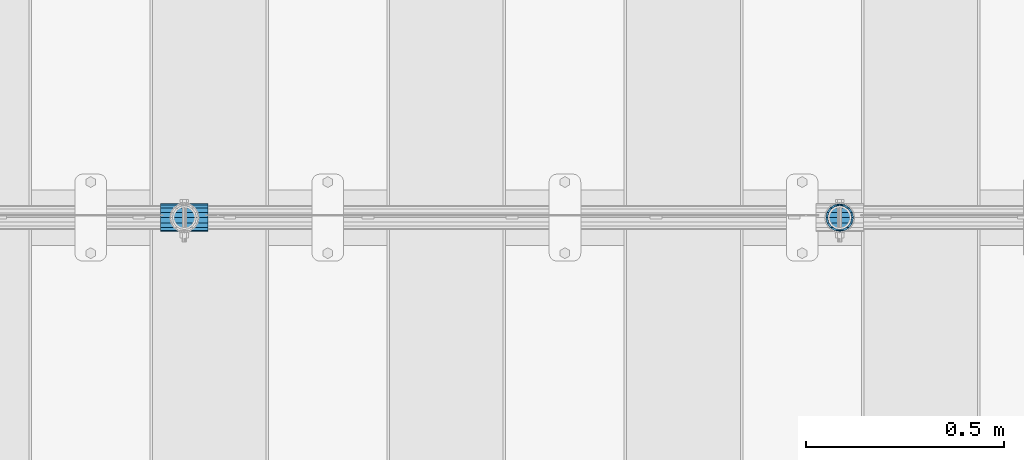
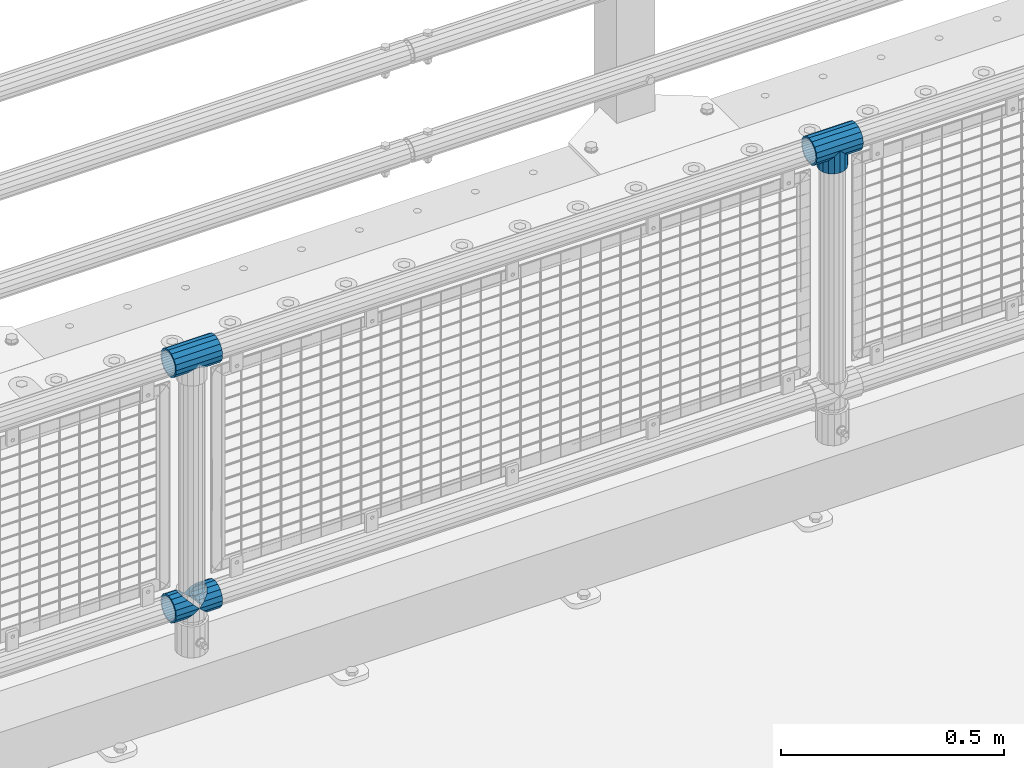
# One storey, part 139 of 219: 5 beams.
"""IFC2X3 building model written with IfcOpenShell, lengths in millimetres."""

from ifc_helpers import new_model, si_unit, frame, origin_with_axes, place, context, subcontext, project, spatial, faceted_brep, material, type_object, element, save


model = new_model("IFC2X3")

# Units and contexts
model_context = context("Model", 3, precision=1e-05, world=origin_with_axes())
body_context = subcontext(model_context, "Body", "Model", "MODEL_VIEW")
ifc_project = project(units=[si_unit("LENGTHUNIT", "METRE", prefix="MILLI"), si_unit("AREAUNIT", "SQUARE_METRE"), si_unit("VOLUMEUNIT", "CUBIC_METRE"), si_unit("MASSUNIT", "GRAM", prefix="KILO"), si_unit("TIMEUNIT", "SECOND"), si_unit("PLANEANGLEUNIT", "RADIAN"), si_unit("SOLIDANGLEUNIT", "STERADIAN"), si_unit("THERMODYNAMICTEMPERATUREUNIT", "DEGREE_CELSIUS"), si_unit("LUMINOUSINTENSITYUNIT", "LUMEN")], contexts=[model_context])

# Site, building, storey
site_placement = place(None, origin_with_axes())
site = spatial("IfcSite", under=ifc_project, at=site_placement, CompositionType="ELEMENT")
building_placement = place(site_placement, origin_with_axes())
building = spatial("IfcBuilding", under=site, at=building_placement, Name="Standard", CompositionType="ELEMENT")
storey_placement = place(building_placement, origin_with_axes())
storey = spatial("IfcBuildingStorey", under=building, at=storey_placement, Name="Undefined", CompositionType="ELEMENT", Elevation=0.0)

# Beams
ifc_material = material(Name="Misc_Undefined")
beam_type = type_object("IfcBeamType", PredefinedType="NOTDEFINED")
beam_1_placement = place(storey_placement, frame((5595.0, 31664.5, 969.849999999999), z_axis=(0.0, 1.0, 0.0), x_axis=(0.0, 0.0, -1.0)))
element("IfcBeam", 1, at=beam_1_placement, inside=storey, type_object=beam_type, material=ifc_material, context=body_context, shape_type="Brep", body=[
    faceted_brep([(0.0, 0.0, 35.1500000000015), (13.4513226476338, 13.4513226476329, 32.4743655677703), (13.4513226476338, -13.4513226476329, 32.4743655677703), (24.8548033587067, -16.3810424080013, -24.8548033587067), (24.8548033587067, -24.8548033587072, -24.8548033587067), (32.4743655677721, -32.4743655677717, -13.4513226476338), (32.4743655677721, -26.8123795176712, -13.4513226476338), (27.1226768591077, -21.4606908090117, -21.46069080901), (0.0, 0.0, -35.1500000000015), (13.4513226476338, -13.4513226476329, -32.4743655677703), (13.4513226476338, 13.4513226476329, -32.4743655677703), (20.0882031229739, -11.6144421722805, -28.0397438117179), (16.6306603983649, 0.0, -30.3499999999985), (20.0882031229739, 11.6144421722805, -28.0397438117179), (24.8548033587067, 16.3810424080013, -24.8548033587067), (24.8548033587067, 24.8548033587072, -24.8548033587067), (27.1226768591077, 21.4606908090117, -21.46069080901), (32.4743655677721, 26.8123795176755, -13.4513226476338), (32.4743655677721, 32.4743655677717, -13.4513226476338), (32.8397438117172, 28.0397438117175, -11.614442172282), (35.1499999999996, 30.35, 0.0), (35.1499999999996, 35.15, 0.0), (32.8397438117172, 28.0397438117175, 11.614442172282), (32.4743655677721, 26.8123795176755, 13.4513226476338), (32.4743655677721, 32.4743655677717, 13.4513226476338), (27.1226768591096, 21.4606908090117, 21.46069080901), (24.8548033587067, 16.3810424080078, 24.8548033587067), (24.8548033587067, 24.8548033587072, 24.8548033587067), (20.0882031229849, 11.6144421722805, 28.0397438117179), (16.6306603983739, 0.0, 30.3499999999985), (20.0882031229849, -11.6144421722805, 28.0397438117179), (24.8548033587067, -16.3810424080013, 24.8548033587067), (24.8548033587067, -24.8548033587072, 24.8548033587067), (27.1226768591096, -21.4606908090117, 21.46069080901), (32.4743655677721, -26.8123795176755, 13.4513226476338), (32.4743655677721, -32.4743655677717, 13.4513226476338), (32.8397438117172, -28.0397438117175, 11.614442172282), (35.1499999999996, -30.35, 0.0), (35.1499999999996, -35.15, 0.0), (32.8397438117172, -28.0397438117175, -11.614442172282), (60.1499999999996, -24.8548033587072, -24.8548033587067), (60.1499999999996, -32.4743655677717, -13.4513226476338), (60.1499999999996, -13.4513226476329, -32.4743655677703), (60.1499999999996, 0.0, -35.1500000000015), (60.1499999999996, 13.4513226476329, -32.4743655677703), (60.1499999999996, 24.8548033587072, -24.8548033587067), (60.1499999999996, 32.4743655677717, -13.4513226476338), (60.1499999999996, 35.15, 0.0), (60.1499999999996, 32.4743655677717, 13.4513226476338), (60.1499999999996, 24.8548033587072, 24.8548033587067), (60.1499999999996, 13.4513226476329, 32.4743655677703), (60.1499999999996, 0.0, 35.1500000000015), (60.1499999999996, -13.4513226476329, 32.4743655677703), (60.1499999999996, -24.8548033587072, 24.8548033587067), (60.1499999999996, -32.4743655677717, 13.4513226476338), (60.1499999999996, -35.15, 0.0), (60.1499999999996, -21.4606908090117, 21.46069080901), (60.1499999999996, -11.6144421722805, 28.0397438117179), (60.1499999999996, 0.0, 30.3499999999985), (60.1499999999996, 11.6144421722805, 28.0397438117179), (60.1499999999996, 21.4606908090117, 21.46069080901), (60.1499999999996, 28.0397438117175, 11.614442172282), (60.1499999999996, 30.35, 0.0), (60.1499999999996, 28.0397438117175, -11.614442172282), (60.1499999999996, 21.4606908090117, -21.46069080901), (60.1499999999996, 11.6144421722805, -28.0397438117179), (60.1499999999996, 0.0, -30.3499999999985), (60.1499999999996, -11.6144421722805, -28.0397438117179), (60.1499999999996, -21.4606908090117, -21.46069080901), (60.1499999999996, -28.0397438117175, -11.614442172282), (60.1499999999996, -30.35, 0.0), (60.1499999999996, -28.0397438117175, 11.614442172282)], [[[0, 1, 2]], [[3, 4, 5, 6, 7]], [[8, 9, 10]], [[10, 9, 4, 3, 11, 12, 13, 14, 15]], [[15, 14, 16, 17, 18]], [[18, 17, 19, 20, 21]], [[21, 20, 22, 23, 24]], [[24, 23, 25, 26, 27]], [[27, 26, 28, 29, 30, 31, 32, 2, 1]], [[33, 34, 35, 32, 31]], [[36, 37, 38, 35, 34]], [[6, 5, 38, 37, 39]], [[40, 41, 5, 4]], [[42, 40, 4, 9]], [[43, 42, 9, 8]], [[44, 43, 8, 10]], [[45, 44, 10, 15]], [[46, 45, 15, 18]], [[47, 46, 18, 21]], [[48, 47, 21, 24]], [[49, 48, 24, 27]], [[50, 49, 27, 1]], [[51, 50, 1, 0]], [[52, 51, 0, 2]], [[53, 52, 2, 32]], [[54, 53, 32, 35]], [[55, 54, 35, 38]], [[41, 55, 38, 5]], [[40, 42, 43, 44, 45, 46, 47, 48, 49, 50, 51, 52, 53, 54, 55, 41], [56, 57, 58, 59, 60, 61, 62, 63, 64, 65, 66, 67, 68, 69, 70, 71]], [[71, 70, 37, 36]], [[56, 71, 36, 34, 33]], [[57, 56, 33, 31, 30]], [[58, 57, 30, 29]], [[59, 58, 29, 28]], [[25, 60, 59, 28, 26]], [[22, 61, 60, 25, 23]], [[62, 61, 22, 20]], [[63, 62, 20, 19]], [[64, 63, 19, 17, 16]], [[65, 64, 16, 14, 13]], [[66, 65, 13, 12]], [[67, 66, 12, 11]], [[7, 68, 67, 11, 3]], [[39, 69, 68, 7, 6]], [[70, 69, 39, 37]]]),
])
beam_2_placement = place(storey_placement, frame((5534.85, 31664.5, 969.849999999999), z_axis=(0.0, 0.0, 1.0), x_axis=(1.0, 0.0, 0.0)))
element("IfcBeam", 2, at=beam_2_placement, inside=storey, type_object=beam_type, material=ifc_material, context=body_context, shape_type="Brep", body=[
    faceted_brep([(88.1897438117176, -11.614442172282, -28.0397438117176), (88.1897438117176, -11.614442172282, -32.8397438117162), (86.9623795176776, -13.4513226476338, -32.4743655677718), (81.6106908090114, -21.46069080901, -27.1226768591079), (81.6106908090114, -21.46069080901, -21.4606908090117), (76.5310424080035, -24.8548033587067, -24.8548033587072), (71.7644421722798, -28.0397438117179, -20.0882031229796), (71.7644421722798, -28.0397438117179, -11.6144421722805), (60.1499999999996, -30.3499999999985, -16.6306603983671), (60.1499999999996, -30.35, 0.0), (48.5355578277195, -28.0397438117179, -20.0882031229796), (48.5355578277195, -28.0397438117179, -11.6144421722805), (43.7689575919958, -24.8548033587067, -24.8548033587072), (38.6893091909878, -21.46069080901, -27.1226768591079), (38.6893091909878, -21.46069080901, -21.4606908090117), (33.3376204823271, -13.4513226476338, -32.4743655677718), (32.1102561882817, -11.614442172282, -32.8397438117162), (32.1102561882817, -11.614442172282, -28.0397438117176), (29.7999999999993, 0.0, -35.15), (29.7999999999993, 0.0, -30.35), (32.1102561882817, 11.614442172282, -32.8397438117171), (32.1102561882817, 11.614442172282, -28.0397438117176), (33.3376204823217, 13.4513226476338, -32.4743655677718), (38.6893091909878, 21.46069080901, -27.1226768591122), (38.6893091909878, 21.46069080901, -21.4606908090117), (43.7689575919958, 24.8548033587067, -24.8548033587072), (48.5355578277195, 28.0397438117179, -20.0882031229861), (48.5355578277195, 28.0397438117179, -11.6144421722805), (60.1499999999996, 30.3499999999985, -16.6306603983737), (60.1499999999996, 30.35, 0.0), (71.7644421722798, 28.0397438117179, -20.0882031229861), (71.7644421722798, 28.0397438117179, -11.6144421722805), (76.5310424080035, 24.8548033587067, -24.8548033587072), (81.6106908090114, 21.46069080901, -27.1226768591122), (81.6106908090114, 21.46069080901, -21.4606908090117), (86.9623795176722, 13.4513226476338, -32.4743655677718), (88.1897438117176, 11.614442172282, -32.8397438117171), (88.1897438117176, 11.614442172282, -28.0397438117176), (90.5, 0.0, -35.15), (90.5, 0.0, -30.35), (0.0, -21.46069080901, -21.4606908090118), (0.0, -28.0397438117179, -11.6144421722802), (0.0, -11.614442172282, -28.0397438117179), (0.0, 0.0, -30.3500000000004), (0.0, 11.614442172282, -28.0397438117179), (0.0, 21.46069080901, -21.4606908090118), (0.0, 28.0397438117179, -11.6144421722802), (0.0, 30.3499999999985, 0.0), (0.0, 32.4743655677703, -13.4513226476338), (0.0, 35.1500000000015, 0.0), (120.299999999999, 35.1500000000015, 0.0), (120.299999999999, 32.4743655677703, -13.4513226476329), (0.0, 32.4743655677703, 13.4513226476338), (120.299999999999, 32.4743655677703, 13.4513226476329), (0.0, 24.8548033587067, 24.8548033587067), (120.299999999999, 24.8548033587067, 24.8548033587072), (0.0, 13.4513226476338, 32.4743655677721), (120.299999999999, 13.4513226476338, 32.4743655677718), (0.0, 0.0, 35.1500000000015), (120.299999999999, 0.0, 35.15), (0.0, -13.4513226476338, 32.4743655677721), (120.299999999999, -13.4513226476338, 32.4743655677718), (0.0, -24.8548033587067, 24.8548033587067), (120.299999999999, -24.8548033587067, 24.8548033587072), (0.0, -32.4743655677703, 13.4513226476338), (120.299999999999, -32.4743655677703, 13.4513226476329), (0.0, -35.1500000000015, 0.0), (120.299999999999, -35.1500000000015, 0.0), (0.0, -32.4743655677703, -13.4513226476338), (120.299999999999, -32.4743655677703, -13.4513226476329), (0.0, 24.8548033587067, -24.8548033587067), (0.0, 13.4513226476338, -32.4743655677721), (0.0, 0.0, -35.1500000000015), (0.0, -13.4513226476338, -32.4743655677721), (0.0, -24.8548033587067, -24.8548033587067), (0.0, 28.0397438117179, 11.6144421722802), (0.0, 21.46069080901, 21.4606908090118), (0.0, 11.614442172282, 28.0397438117179), (0.0, 0.0, 30.3500000000004), (0.0, -11.614442172282, 28.0397438117179), (0.0, -21.46069080901, 21.4606908090118), (0.0, -28.0397438117179, 11.6144421722802), (0.0, -30.3499999999985, 0.0), (120.299999999999, -30.3499999999985, 0.0), (120.299999999999, -28.0397438117179, -11.6144421722805), (120.299999999999, -21.46069080901, -21.4606908090117), (120.299999999999, -11.614442172282, -28.0397438117176), (120.299999999999, 0.0, -30.35), (120.299999999999, 21.46069080901, -21.4606908090117), (120.299999999999, 28.0397438117179, -11.6144421722805), (120.299999999999, 11.614442172282, -28.0397438117176), (120.299999999999, 30.3499999999985, 0.0), (120.299999999999, 28.0397438117179, 11.6144421722805), (120.299999999999, 21.46069080901, 21.4606908090117), (120.299999999999, 11.614442172282, 28.0397438117176), (120.299999999999, 0.0, 30.35), (120.299999999999, -11.614442172282, 28.0397438117176), (120.299999999999, -21.46069080901, 21.4606908090117), (120.299999999999, -28.0397438117179, 11.6144421722805), (120.299999999999, -24.8548033587067, -24.8548033587072), (120.299999999999, -13.4513226476338, -32.4743655677718), (120.299999999999, 0.0, -35.15), (120.299999999999, 13.4513226476338, -32.4743655677718), (120.299999999999, 24.8548033587067, -24.8548033587072)], [[[0, 1, 2, 3, 4]], [[4, 3, 5, 6, 7]], [[7, 6, 8, 9]], [[9, 8, 10, 11]], [[11, 10, 12, 13, 14]], [[14, 13, 15, 16, 17]], [[17, 16, 18, 19]], [[19, 18, 20, 21]], [[21, 20, 22, 23, 24]], [[24, 23, 25, 26, 27]], [[27, 26, 28, 29]], [[29, 28, 30, 31]], [[31, 30, 32, 33, 34]], [[34, 33, 35, 36, 37]], [[37, 36, 38, 39]], [[39, 38, 1, 0]], [[40, 41, 11, 14]], [[42, 40, 14, 17]], [[43, 42, 17, 19]], [[44, 43, 19, 21]], [[45, 44, 21, 24]], [[46, 45, 24, 27]], [[47, 46, 27, 29]], [[48, 49, 50, 51]], [[49, 52, 53, 50]], [[52, 54, 55, 53]], [[54, 56, 57, 55]], [[56, 58, 59, 57]], [[58, 60, 61, 59]], [[60, 62, 63, 61]], [[62, 64, 65, 63]], [[64, 66, 67, 65]], [[66, 68, 69, 67]], [[64, 62, 60, 58, 56, 54, 52, 49, 48, 70, 71, 72, 73, 74, 68, 66], [41, 40, 42, 43, 44, 45, 46, 47, 75, 76, 77, 78, 79, 80, 81, 82]], [[41, 82, 9, 11]], [[83, 84, 7, 9]], [[84, 85, 4, 7]], [[85, 86, 0, 4]], [[86, 87, 39, 0]], [[88, 89, 31, 34]], [[90, 88, 34, 37]], [[87, 90, 37, 39]], [[89, 91, 29, 31]], [[75, 47, 29, 91, 92]], [[76, 75, 92, 93]], [[77, 76, 93, 94]], [[78, 77, 94, 95]], [[79, 78, 95, 96]], [[80, 79, 96, 97]], [[81, 80, 97, 98]], [[9, 82, 81, 98, 83]], [[99, 100, 101, 102, 103, 51, 50, 53, 55, 57, 59, 61, 63, 65, 67, 69], [97, 96, 95, 94, 93, 92, 91, 89, 88, 90, 87, 86, 85, 84, 83, 98]], [[35, 102, 101, 38, 36]], [[32, 103, 102, 35, 33]], [[28, 26, 25, 70, 48, 51, 103, 32, 30]], [[22, 71, 70, 25, 23]], [[18, 72, 71, 22, 20]], [[73, 72, 18, 16, 15]], [[74, 73, 15, 13, 12]], [[99, 69, 68, 74, 12, 10, 8, 6, 5]], [[100, 99, 5, 3, 2]], [[101, 100, 2, 1, 38]]]),
])
beam_3_placement = place(storey_placement, frame((3876.85, 31664.5, 969.849999999999), z_axis=(0.0, 0.0, 1.0), x_axis=(1.0, 0.0, 0.0)))
element("IfcBeam", 3, at=beam_3_placement, inside=storey, type_object=beam_type, material=ifc_material, context=body_context, shape_type="Brep", body=[
    faceted_brep([(88.1897438117176, -11.614442172282, -28.0397438117176), (88.1897438117176, -11.614442172282, -32.8397438117162), (86.9623795176776, -13.4513226476338, -32.4743655677718), (81.6106908090114, -21.46069080901, -27.1226768591079), (81.6106908090114, -21.46069080901, -21.4606908090117), (76.5310424080035, -24.8548033587067, -24.8548033587072), (71.7644421722798, -28.0397438117179, -20.0882031229796), (71.7644421722798, -28.0397438117179, -11.6144421722805), (60.1499999999996, -30.3499999999985, -16.6306603983671), (60.1499999999996, -30.35, 0.0), (48.5355578277195, -28.0397438117179, -20.0882031229796), (48.5355578277195, -28.0397438117179, -11.6144421722805), (43.7689575919958, -24.8548033587067, -24.8548033587072), (38.6893091909878, -21.46069080901, -27.1226768591079), (38.6893091909878, -21.46069080901, -21.4606908090117), (33.3376204823271, -13.4513226476338, -32.4743655677718), (32.1102561882817, -11.614442172282, -32.8397438117162), (32.1102561882817, -11.614442172282, -28.0397438117176), (29.7999999999993, 0.0, -35.15), (29.7999999999993, 0.0, -30.35), (32.1102561882817, 11.614442172282, -32.8397438117171), (32.1102561882817, 11.614442172282, -28.0397438117176), (33.3376204823217, 13.4513226476338, -32.4743655677718), (38.6893091909878, 21.46069080901, -27.1226768591122), (38.6893091909878, 21.46069080901, -21.4606908090117), (43.7689575919958, 24.8548033587067, -24.8548033587072), (48.5355578277195, 28.0397438117179, -20.0882031229861), (48.5355578277195, 28.0397438117179, -11.6144421722805), (60.1499999999996, 30.3499999999985, -16.6306603983737), (60.1499999999996, 30.35, 0.0), (71.7644421722798, 28.0397438117179, -20.0882031229861), (71.7644421722798, 28.0397438117179, -11.6144421722805), (76.5310424080035, 24.8548033587067, -24.8548033587072), (81.6106908090114, 21.46069080901, -27.1226768591122), (81.6106908090114, 21.46069080901, -21.4606908090117), (86.9623795176722, 13.4513226476338, -32.4743655677718), (88.1897438117176, 11.614442172282, -32.8397438117171), (88.1897438117176, 11.614442172282, -28.0397438117176), (90.5, 0.0, -35.15), (90.5, 0.0, -30.35), (0.0, -21.46069080901, -21.4606908090118), (0.0, -28.0397438117179, -11.6144421722802), (0.0, -11.614442172282, -28.0397438117179), (0.0, 0.0, -30.3500000000004), (0.0, 11.614442172282, -28.0397438117179), (0.0, 21.46069080901, -21.4606908090118), (0.0, 28.0397438117179, -11.6144421722802), (0.0, 30.3499999999985, 0.0), (0.0, 32.4743655677703, -13.4513226476338), (0.0, 35.1500000000015, 0.0), (120.299999999999, 35.1500000000015, 0.0), (120.299999999999, 32.4743655677703, -13.4513226476329), (0.0, 32.4743655677703, 13.4513226476338), (120.299999999999, 32.4743655677703, 13.4513226476329), (0.0, 24.8548033587067, 24.8548033587067), (120.299999999999, 24.8548033587067, 24.8548033587072), (0.0, 13.4513226476338, 32.4743655677721), (120.299999999999, 13.4513226476338, 32.4743655677718), (0.0, 0.0, 35.1500000000015), (120.299999999999, 0.0, 35.15), (0.0, -13.4513226476338, 32.4743655677721), (120.299999999999, -13.4513226476338, 32.4743655677718), (0.0, -24.8548033587067, 24.8548033587067), (120.299999999999, -24.8548033587067, 24.8548033587072), (0.0, -32.4743655677703, 13.4513226476338), (120.299999999999, -32.4743655677703, 13.4513226476329), (0.0, -35.1500000000015, 0.0), (120.299999999999, -35.1500000000015, 0.0), (0.0, -32.4743655677703, -13.4513226476338), (120.299999999999, -32.4743655677703, -13.4513226476329), (0.0, 24.8548033587067, -24.8548033587067), (0.0, 13.4513226476338, -32.4743655677721), (0.0, 0.0, -35.1500000000015), (0.0, -13.4513226476338, -32.4743655677721), (0.0, -24.8548033587067, -24.8548033587067), (0.0, 28.0397438117179, 11.6144421722802), (0.0, 21.46069080901, 21.4606908090118), (0.0, 11.614442172282, 28.0397438117179), (0.0, 0.0, 30.3500000000004), (0.0, -11.614442172282, 28.0397438117179), (0.0, -21.46069080901, 21.4606908090118), (0.0, -28.0397438117179, 11.6144421722802), (0.0, -30.3499999999985, 0.0), (120.299999999999, -30.3499999999985, 0.0), (120.299999999999, -28.0397438117179, -11.6144421722805), (120.299999999999, -21.46069080901, -21.4606908090117), (120.299999999999, -11.614442172282, -28.0397438117176), (120.299999999999, 0.0, -30.35), (120.299999999999, 21.46069080901, -21.4606908090117), (120.299999999999, 28.0397438117179, -11.6144421722805), (120.299999999999, 11.614442172282, -28.0397438117176), (120.299999999999, 30.3499999999985, 0.0), (120.299999999999, 28.0397438117179, 11.6144421722805), (120.299999999999, 21.46069080901, 21.4606908090117), (120.299999999999, 11.614442172282, 28.0397438117176), (120.299999999999, 0.0, 30.35), (120.299999999999, -11.614442172282, 28.0397438117176), (120.299999999999, -21.46069080901, 21.4606908090117), (120.299999999999, -28.0397438117179, 11.6144421722805), (120.299999999999, -24.8548033587067, -24.8548033587072), (120.299999999999, -13.4513226476338, -32.4743655677718), (120.299999999999, 0.0, -35.15), (120.299999999999, 13.4513226476338, -32.4743655677718), (120.299999999999, 24.8548033587067, -24.8548033587072)], [[[0, 1, 2, 3, 4]], [[4, 3, 5, 6, 7]], [[7, 6, 8, 9]], [[9, 8, 10, 11]], [[11, 10, 12, 13, 14]], [[14, 13, 15, 16, 17]], [[17, 16, 18, 19]], [[19, 18, 20, 21]], [[21, 20, 22, 23, 24]], [[24, 23, 25, 26, 27]], [[27, 26, 28, 29]], [[29, 28, 30, 31]], [[31, 30, 32, 33, 34]], [[34, 33, 35, 36, 37]], [[37, 36, 38, 39]], [[39, 38, 1, 0]], [[40, 41, 11, 14]], [[42, 40, 14, 17]], [[43, 42, 17, 19]], [[44, 43, 19, 21]], [[45, 44, 21, 24]], [[46, 45, 24, 27]], [[47, 46, 27, 29]], [[48, 49, 50, 51]], [[49, 52, 53, 50]], [[52, 54, 55, 53]], [[54, 56, 57, 55]], [[56, 58, 59, 57]], [[58, 60, 61, 59]], [[60, 62, 63, 61]], [[62, 64, 65, 63]], [[64, 66, 67, 65]], [[66, 68, 69, 67]], [[64, 62, 60, 58, 56, 54, 52, 49, 48, 70, 71, 72, 73, 74, 68, 66], [41, 40, 42, 43, 44, 45, 46, 47, 75, 76, 77, 78, 79, 80, 81, 82]], [[41, 82, 9, 11]], [[83, 84, 7, 9]], [[84, 85, 4, 7]], [[85, 86, 0, 4]], [[86, 87, 39, 0]], [[88, 89, 31, 34]], [[90, 88, 34, 37]], [[87, 90, 37, 39]], [[89, 91, 29, 31]], [[75, 47, 29, 91, 92]], [[76, 75, 92, 93]], [[77, 76, 93, 94]], [[78, 77, 94, 95]], [[79, 78, 95, 96]], [[80, 79, 96, 97]], [[81, 80, 97, 98]], [[9, 82, 81, 98, 83]], [[99, 100, 101, 102, 103, 51, 50, 53, 55, 57, 59, 61, 63, 65, 67, 69], [97, 96, 95, 94, 93, 92, 91, 89, 88, 90, 87, 86, 85, 84, 83, 98]], [[35, 102, 101, 38, 36]], [[32, 103, 102, 35, 33]], [[28, 26, 25, 70, 48, 51, 103, 32, 30]], [[22, 71, 70, 25, 23]], [[18, 72, 71, 22, 20]], [[73, 72, 18, 16, 15]], [[74, 73, 15, 13, 12]], [[99, 69, 68, 74, 12, 10, 8, 6, 5]], [[100, 99, 5, 3, 2]], [[101, 100, 2, 1, 38]]]),
])
beam_4_placement = place(storey_placement, frame((3876.85, 31664.5, 298.17), z_axis=(0.0, 1.0, 0.0), x_axis=(1.0, 0.0, 0.0)))
element("IfcBeam", 4, at=beam_4_placement, inside=storey, type_object=beam_type, material=ifc_material, context=body_context, shape_type="Brep", body=[
    faceted_brep([(60.1499999999996, 0.0, -35.1500000000015), (46.6986773523668, 13.4513226476329, -32.4743655677703), (46.6986773523668, -13.4513226476329, -32.4743655677703), (33.0273231408928, 21.4606908090117, 21.46069080901), (27.675634432228, 26.8123795176712, 13.4513226476338), (27.675634432228, 32.4743655677717, 13.4513226476338), (35.2951966412925, 24.8548033587072, 24.8548033587067), (35.2951966412925, 16.3810424080078, 24.8548033587067), (27.3102561882824, 28.0397438117175, 11.614442172282), (24.9999999999995, 30.35, 0.0), (24.9999999999995, 35.15, 0.0), (27.675634432228, 26.8123795176755, -13.4513226476338), (27.675634432228, 32.4743655677717, -13.4513226476338), (27.3102561882829, 28.0397438117175, -11.614442172282), (35.2951966412925, 16.3810424080013, -24.8548033587067), (35.2951966412925, 24.8548033587072, -24.8548033587067), (33.0273231408896, 21.4606908090117, -21.46069080901), (40.0617968770143, 11.6144421722805, -28.0397438117179), (43.5193396016266, 0.0, -30.3499999999985), (40.0617968770143, -11.6144421722805, -28.0397438117179), (35.2951966412925, -16.3810424080013, -24.8548033587067), (35.2951966412925, -24.8548033587072, -24.8548033587067), (33.0273231408896, -21.4606908090117, -21.46069080901), (27.675634432228, -26.8123795176755, -13.4513226476338), (27.675634432228, -32.4743655677717, -13.4513226476338), (27.3102561882829, -28.0397438117175, -11.614442172282), (24.9999999999995, -30.35, 0.0), (24.9999999999995, -35.15, 0.0), (27.3102561882824, -28.0397438117175, 11.614442172282), (27.675634432228, -26.8123795176755, 13.4513226476338), (27.675634432228, -32.4743655677717, 13.4513226476338), (33.0273231408928, -21.4606908090117, 21.46069080901), (35.2951966412925, -16.3810424080013, 24.8548033587067), (35.2951966412925, -24.8548033587072, 24.8548033587067), (60.1499999999996, 0.0, 35.1500000000015), (46.6986773523668, -13.4513226476329, 32.4743655677703), (46.6986773523668, 13.4513226476329, 32.4743655677703), (40.0617968770207, -11.6144421722805, 28.0397438117179), (43.519339601633, 0.0, 30.3499999999985), (40.0617968770207, 11.6144421722805, 28.0397438117179), (0.0, -32.4743655677703, -13.4513226476338), (0.0, -24.8548033587067, -24.8548033587067), (0.0, -13.4513226476338, -32.4743655677721), (0.0, 0.0, -35.1500000000015), (0.0, 13.4513226476338, -32.4743655677721), (0.0, 24.8548033587067, -24.8548033587067), (0.0, 32.4743655677703, -13.4513226476338), (0.0, 35.1500000000015, 0.0), (0.0, 32.4743655677703, 13.4513226476338), (0.0, 24.8548033587067, 24.8548033587067), (0.0, 13.4513226476338, 32.4743655677721), (0.0, 0.0, 35.1500000000015), (0.0, -32.4743655677703, 13.4513226476338), (0.0, -35.1500000000015, 0.0), (0.0, -24.8548033587067, 24.8548033587067), (0.0, -13.4513226476338, 32.4743655677721), (0.0, -28.0397438117179, -11.6144421722802), (0.0, -21.46069080901, -21.4606908090118), (0.0, -11.614442172282, -28.0397438117179), (0.0, 0.0, -30.3500000000004), (0.0, 11.614442172282, -28.0397438117179), (0.0, 21.46069080901, -21.4606908090118), (0.0, 28.0397438117179, -11.6144421722802), (0.0, 30.3499999999985, 0.0), (0.0, 28.0397438117179, 11.6144421722802), (0.0, 21.46069080901, 21.4606908090118), (0.0, 11.614442172282, 28.0397438117179), (0.0, 0.0, 30.3500000000004), (0.0, -11.614442172282, 28.0397438117179), (0.0, -21.46069080901, 21.4606908090118), (0.0, -28.0397438117179, 11.6144421722802), (0.0, -30.3499999999985, 0.0)], [[[0, 1, 2]], [[3, 4, 5, 6, 7]], [[8, 9, 10, 5, 4]], [[11, 12, 10, 9, 13]], [[14, 15, 12, 11, 16]], [[2, 1, 15, 14, 17, 18, 19, 20, 21]], [[21, 20, 22, 23, 24]], [[24, 23, 25, 26, 27]], [[27, 26, 28, 29, 30]], [[30, 29, 31, 32, 33]], [[34, 35, 36]], [[33, 32, 37, 38, 39, 7, 6, 36, 35]], [[40, 41, 21, 24]], [[41, 42, 2, 21]], [[42, 43, 0, 2]], [[43, 44, 1, 0]], [[44, 45, 15, 1]], [[45, 46, 12, 15]], [[46, 47, 10, 12]], [[47, 48, 5, 10]], [[48, 49, 6, 5]], [[49, 50, 36, 6]], [[50, 51, 34, 36]], [[52, 53, 27, 30]], [[54, 52, 30, 33]], [[55, 54, 33, 35]], [[51, 55, 35, 34]], [[53, 40, 24, 27]], [[52, 54, 55, 51, 50, 49, 48, 47, 46, 45, 44, 43, 42, 41, 40, 53], [56, 57, 58, 59, 60, 61, 62, 63, 64, 65, 66, 67, 68, 69, 70, 71]], [[68, 67, 38, 37]], [[31, 69, 68, 37, 32]], [[28, 70, 69, 31, 29]], [[71, 70, 28, 26]], [[56, 71, 26, 25]], [[57, 56, 25, 23, 22]], [[58, 57, 22, 20, 19]], [[59, 58, 19, 18]], [[60, 59, 18, 17]], [[16, 61, 60, 17, 14]], [[13, 62, 61, 16, 11]], [[63, 62, 13, 9]], [[64, 63, 9, 8]], [[65, 64, 8, 4, 3]], [[66, 65, 3, 7, 39]], [[67, 66, 39, 38]]]),
])
beam_5_placement = place(storey_placement, frame((3937.0, 31664.5, 298.17), z_axis=(0.0, 1.0, 0.0), x_axis=(1.0, 0.0, 0.0)))
element("IfcBeam", 5, at=beam_5_placement, inside=storey, type_object=beam_type, material=ifc_material, context=body_context, shape_type="Brep", body=[
    faceted_brep([(0.0, 0.0, 35.1500000000015), (13.4513226476338, 13.4513226476329, 32.4743655677703), (13.4513226476338, -13.4513226476329, 32.4743655677703), (24.8548033587067, -16.3810424080013, -24.8548033587067), (24.8548033587067, -24.8548033587072, -24.8548033587067), (32.4743655677721, -32.4743655677717, -13.4513226476338), (32.4743655677721, -26.8123795176712, -13.4513226476338), (27.1226768591077, -21.4606908090117, -21.46069080901), (0.0, 0.0, -35.1500000000015), (13.4513226476338, -13.4513226476329, -32.4743655677703), (13.4513226476338, 13.4513226476329, -32.4743655677703), (20.0882031229739, -11.6144421722805, -28.0397438117179), (16.6306603983649, 0.0, -30.3499999999985), (20.0882031229739, 11.6144421722805, -28.0397438117179), (24.8548033587067, 16.3810424080013, -24.8548033587067), (24.8548033587067, 24.8548033587072, -24.8548033587067), (27.1226768591077, 21.4606908090117, -21.46069080901), (32.4743655677721, 26.8123795176755, -13.4513226476338), (32.4743655677721, 32.4743655677717, -13.4513226476338), (32.8397438117172, 28.0397438117175, -11.614442172282), (35.1499999999996, 30.35, 0.0), (35.1499999999996, 35.15, 0.0), (32.8397438117172, 28.0397438117175, 11.614442172282), (32.4743655677721, 26.8123795176755, 13.4513226476338), (32.4743655677721, 32.4743655677717, 13.4513226476338), (27.1226768591096, 21.4606908090117, 21.46069080901), (24.8548033587067, 16.3810424080078, 24.8548033587067), (24.8548033587067, 24.8548033587072, 24.8548033587067), (20.0882031229849, 11.6144421722805, 28.0397438117179), (16.6306603983739, 0.0, 30.3499999999985), (20.0882031229849, -11.6144421722805, 28.0397438117179), (24.8548033587067, -16.3810424080013, 24.8548033587067), (24.8548033587067, -24.8548033587072, 24.8548033587067), (27.1226768591096, -21.4606908090117, 21.46069080901), (32.4743655677721, -26.8123795176755, 13.4513226476338), (32.4743655677721, -32.4743655677717, 13.4513226476338), (32.8397438117172, -28.0397438117175, 11.614442172282), (35.1499999999996, -30.35, 0.0), (35.1499999999996, -35.15, 0.0), (32.8397438117172, -28.0397438117175, -11.614442172282), (60.1499999999996, -24.8548033587072, -24.8548033587067), (60.1499999999996, -32.4743655677717, -13.4513226476338), (60.1499999999996, -13.4513226476329, -32.4743655677703), (60.1499999999996, 0.0, -35.1500000000015), (60.1499999999996, 13.4513226476329, -32.4743655677703), (60.1499999999996, 24.8548033587072, -24.8548033587067), (60.1499999999996, 32.4743655677717, -13.4513226476338), (60.1499999999996, 35.15, 0.0), (60.1499999999996, 32.4743655677717, 13.4513226476338), (60.1499999999996, 24.8548033587072, 24.8548033587067), (60.1499999999996, 13.4513226476329, 32.4743655677703), (60.1499999999996, 0.0, 35.1500000000015), (60.1499999999996, -13.4513226476329, 32.4743655677703), (60.1499999999996, -24.8548033587072, 24.8548033587067), (60.1499999999996, -32.4743655677717, 13.4513226476338), (60.1499999999996, -35.15, 0.0), (60.1499999999996, -21.4606908090117, 21.46069080901), (60.1499999999996, -11.6144421722805, 28.0397438117179), (60.1499999999996, 0.0, 30.3499999999985), (60.1499999999996, 11.6144421722805, 28.0397438117179), (60.1499999999996, 21.4606908090117, 21.46069080901), (60.1499999999996, 28.0397438117175, 11.614442172282), (60.1499999999996, 30.35, 0.0), (60.1499999999996, 28.0397438117175, -11.614442172282), (60.1499999999996, 21.4606908090117, -21.46069080901), (60.1499999999996, 11.6144421722805, -28.0397438117179), (60.1499999999996, 0.0, -30.3499999999985), (60.1499999999996, -11.6144421722805, -28.0397438117179), (60.1499999999996, -21.4606908090117, -21.46069080901), (60.1499999999996, -28.0397438117175, -11.614442172282), (60.1499999999996, -30.35, 0.0), (60.1499999999996, -28.0397438117175, 11.614442172282)], [[[0, 1, 2]], [[3, 4, 5, 6, 7]], [[8, 9, 10]], [[10, 9, 4, 3, 11, 12, 13, 14, 15]], [[15, 14, 16, 17, 18]], [[18, 17, 19, 20, 21]], [[21, 20, 22, 23, 24]], [[24, 23, 25, 26, 27]], [[27, 26, 28, 29, 30, 31, 32, 2, 1]], [[33, 34, 35, 32, 31]], [[36, 37, 38, 35, 34]], [[6, 5, 38, 37, 39]], [[40, 41, 5, 4]], [[42, 40, 4, 9]], [[43, 42, 9, 8]], [[44, 43, 8, 10]], [[45, 44, 10, 15]], [[46, 45, 15, 18]], [[47, 46, 18, 21]], [[48, 47, 21, 24]], [[49, 48, 24, 27]], [[50, 49, 27, 1]], [[51, 50, 1, 0]], [[52, 51, 0, 2]], [[53, 52, 2, 32]], [[54, 53, 32, 35]], [[55, 54, 35, 38]], [[41, 55, 38, 5]], [[40, 42, 43, 44, 45, 46, 47, 48, 49, 50, 51, 52, 53, 54, 55, 41], [56, 57, 58, 59, 60, 61, 62, 63, 64, 65, 66, 67, 68, 69, 70, 71]], [[71, 70, 37, 36]], [[56, 71, 36, 34, 33]], [[57, 56, 33, 31, 30]], [[58, 57, 30, 29]], [[59, 58, 29, 28]], [[25, 60, 59, 28, 26]], [[22, 61, 60, 25, 23]], [[62, 61, 22, 20]], [[63, 62, 20, 19]], [[64, 63, 19, 17, 16]], [[65, 64, 16, 14, 13]], [[66, 65, 13, 12]], [[67, 66, 12, 11]], [[7, 68, 67, 11, 3]], [[39, 69, 68, 7, 6]], [[70, 69, 39, 37]]]),
])

save(model, "model.ifc")
